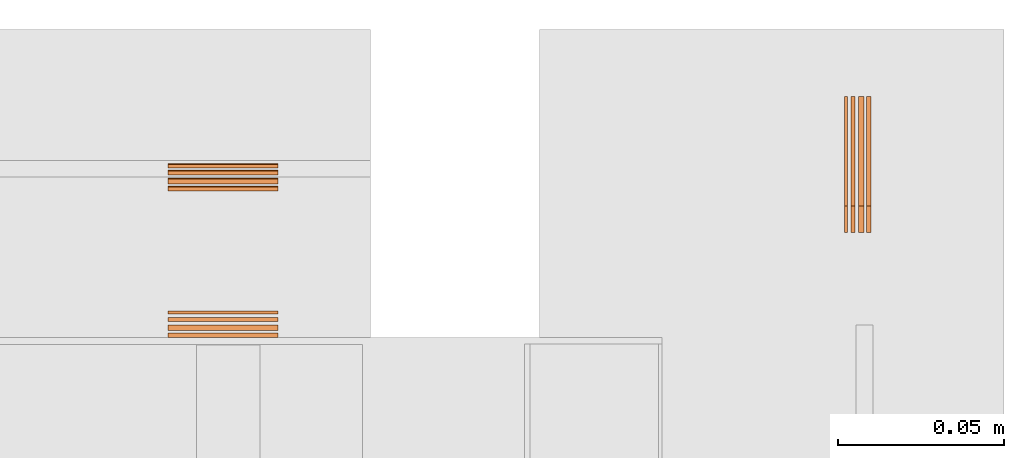
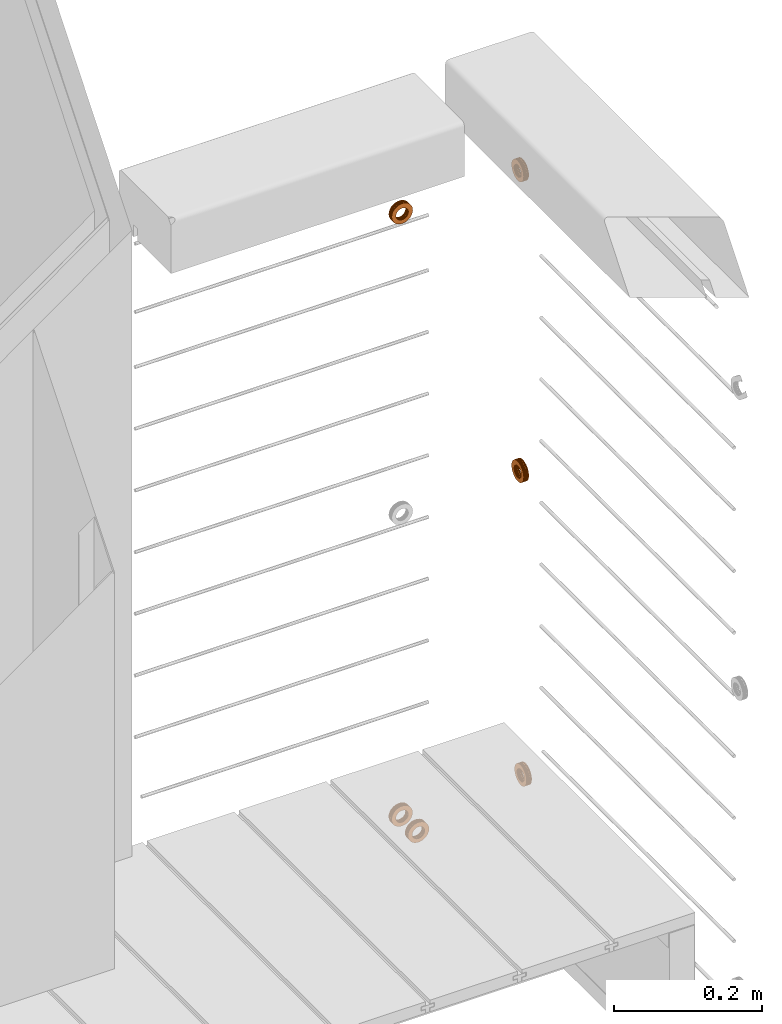
# One storey, part 33 of 33: 6 proxies.
"""IFC4 building model written with IfcOpenShell, lengths in feet."""

import ifcopenshell
import ifcopenshell.guid

model = None  # the IFC model being written
_history = None  # IfcOwnerHistory: only IFC2X3 demands one
_inside = {}  # id of a spatial element -> (the spatial element, [elements in it])
_under = {}  # id of a project, library or spatial element -> (it, [spatial elements below it])
_declared = {}  # id of a project -> (the project, [libraries it declares])
_typed = {}  # id of a type object -> (the type object, [elements of that type])
_made_of = {}  # id of a material, layer set ... -> (it, [elements and type objects made of it])


def new_model(schema):
    """Start an empty IFC model of exactly this schema.

    Asked for "IFC4X3", IfcOpenShell would pick the latest addendum, in which some entities
    have other attributes; the version numbers below select the first issue.
    IFC2X3 requires an IfcOwnerHistory on every rooted entity: one is made here for all.
    """
    global model, _history
    if schema == "IFC4X3":
        model = ifcopenshell.file(schema_version=(4, 3, 0, 0))
    else:
        model = ifcopenshell.file(schema=schema)
    _inside.clear()
    _under.clear()
    _declared.clear()
    _typed.clear()
    _made_of.clear()
    _history = None
    if model.schema == "IFC2X3":
        org = make("IfcOrganization", Name="unknown")
        user = make(
            "IfcPersonAndOrganization",
            ThePerson=make("IfcPerson", FamilyName="unknown"),
            TheOrganization=org,
        )
        app = make(
            "IfcApplication",
            ApplicationDeveloper=org,
            Version="unknown",
            ApplicationFullName="unknown",
            ApplicationIdentifier="unknown",
        )
        _history = make(
            "IfcOwnerHistory",
            OwningUser=user,
            OwningApplication=app,
            ChangeAction="ADDED",
            CreationDate=0,
        )
    return model


def make(cls, **values):
    """One entity of the class cls with the attributes given. An attribute that is None is left unset."""
    return model.create_entity(
        cls, **{name: value for name, value in values.items() if value is not None}
    )


def entity(cls, *values):
    """Any entity or typed value of the class cls, its attributes in the order of the schema. None: left unset."""
    e = model.create_entity(cls)
    for i, value in enumerate(values):
        if value is not None:
            e[i] = value
    return e


def rooted(cls, **values):
    """An entity with a GlobalId (a new one), such as an element, a storey or a relation."""
    return make(cls, GlobalId=ifcopenshell.guid.new(), OwnerHistory=_history, **values)


def si_unit(unit_type, name, prefix=None):
    """IfcSIUnit, for example si_unit("LENGTHUNIT", "METRE", prefix="MILLI")."""
    return make("IfcSIUnit", UnitType=unit_type, Prefix=prefix, Name=name)


def converted_unit(unit_type, name, factor, base, dimensions=None, offset=None):
    """IfcConversionBasedUnit, such as the inch: factor (a typed value) times the base unit."""
    return make(
        "IfcConversionBasedUnit"
        if offset is None
        else "IfcConversionBasedUnitWithOffset",
        ConversionOffset=offset,
        Dimensions=None
        if dimensions is None
        else entity("IfcDimensionalExponents", *dimensions),
        UnitType=unit_type,
        Name=name,
        ConversionFactor=make(
            "IfcMeasureWithUnit", ValueComponent=factor, UnitComponent=base
        ),
    )


def derived_unit(unit_type, elements):
    """IfcDerivedUnit: a product of units, each with its exponent."""
    return make(
        "IfcDerivedUnit",
        Elements=[
            make("IfcDerivedUnitElement", Unit=unit, Exponent=power)
            for unit, power in elements
        ],
        UnitType=unit_type,
    )


def assignment(units):
    """IfcUnitAssignment: the units of a project."""
    return None if units is None else make("IfcUnitAssignment", Units=units)


def point(xyz):
    """IfcCartesianPoint."""
    return None if xyz is None else make("IfcCartesianPoint", Coordinates=xyz)


def direction(xyz):
    """IfcDirection."""
    return None if xyz is None else make("IfcDirection", DirectionRatios=xyz)


def frame(location, z_axis=None, x_axis=None):
    """IfcAxis2Placement3D, a coordinate frame: its origin and axes. An axis left out is left unset."""
    return make(
        "IfcAxis2Placement3D",
        Location=point(location),
        Axis=direction(z_axis),
        RefDirection=direction(x_axis),
    )


def frame_2d(location, x_axis=None):
    """IfcAxis2Placement2D, a coordinate frame in the plane: its origin and x axis."""
    return make(
        "IfcAxis2Placement2D", Location=point(location), RefDirection=direction(x_axis)
    )


def origin():
    """The frame at (0, 0, 0) with its axes left unset."""
    return frame((0.0, 0.0, 0.0))


def origin_2d_with_axis():
    """The frame at (0, 0) in the plane with the x axis (1, 0) written out."""
    return frame_2d((0.0, 0.0), x_axis=(1.0, 0.0))


def place(relative_to, where):
    """IfcLocalPlacement: puts the frame where relative to a parent placement (None: the world)."""
    return make(
        "IfcLocalPlacement", PlacementRelTo=relative_to, RelativePlacement=where
    )


def context(
    kind, dimensions, precision=None, world=None, true_north=None, identifier=None
):
    """IfcGeometricRepresentationContext, for example the 3D "Model" context."""
    return make(
        "IfcGeometricRepresentationContext",
        ContextIdentifier=identifier,
        ContextType=kind,
        CoordinateSpaceDimension=dimensions,
        Precision=precision,
        WorldCoordinateSystem=world,
        TrueNorth=true_north,
    )


def subcontext(parent, identifier, kind, view, scale=None):
    """IfcGeometricRepresentationSubContext, for example "Body" below "Model"."""
    return make(
        "IfcGeometricRepresentationSubContext",
        ContextIdentifier=identifier,
        ContextType=kind,
        ParentContext=parent,
        TargetScale=scale,
        TargetView=view,
    )


def project(units=None, contexts=None):
    """IfcProject with its units and contexts."""
    return rooted(
        "IfcProject",
        Name="project",
        RepresentationContexts=contexts,
        UnitsInContext=assignment(units),
    )


def spatial(cls, under=None, at=None, **own):
    """A site, building, storey or space (cls), placed at a placement, below another one or the project."""
    s = rooted(cls, ObjectPlacement=at, **own)
    if under is not None:
        _under.setdefault(under.id(), (under, []))[1].append(s)
    return s


def circle_curve(where, radius):
    """IfcCircle in the frame where."""
    return make("IfcCircle", Position=where, Radius=radius)


def parameter(value):
    """IfcParameterValue: where a trimmed curve begins or ends, as a parameter of its basis curve."""
    return model.create_entity("IfcParameterValue", value)


def trimmed(basis, trim1, trim2, sense, master):
    """IfcTrimmedCurve: the piece of a basis curve between two trims."""
    return make(
        "IfcTrimmedCurve",
        BasisCurve=basis,
        Trim1=trim1,
        Trim2=trim2,
        SenseAgreement=sense,
        MasterRepresentation=master,
    )


def segment(curve, same_sense, transition):
    """IfcCompositeCurveSegment."""
    return make(
        "IfcCompositeCurveSegment",
        Transition=transition,
        SameSense=same_sense,
        ParentCurve=curve,
    )


def composite_curve(segments, self_intersect=None):
    """IfcCompositeCurve: segments joined end to end."""
    return make("IfcCompositeCurve", Segments=segments, SelfIntersect=self_intersect)


def outline(outer, holes=None, kind="AREA"):
    """IfcArbitraryClosedProfileDef: a profile drawn as a closed curve; with holes, ...WithVoids."""
    if holes is None:
        return make("IfcArbitraryClosedProfileDef", ProfileType=kind, OuterCurve=outer)
    return make(
        "IfcArbitraryProfileDefWithVoids",
        ProfileType=kind,
        OuterCurve=outer,
        InnerCurves=holes,
    )


def extrude(swept, where, along, depth):
    """IfcExtrudedAreaSolid: the profile swept, set in the frame where, extruded along a direction by depth."""
    return make(
        "IfcExtrudedAreaSolid",
        SweptArea=swept,
        Position=where,
        ExtrudedDirection=direction(along),
        Depth=depth,
    )


def shape(context_of_items, identifier, shape_type, items):
    """IfcShapeRepresentation: the items that make up one representation, for example the "Body"."""
    return make(
        "IfcShapeRepresentation",
        ContextOfItems=context_of_items,
        RepresentationIdentifier=identifier,
        RepresentationType=shape_type,
        Items=items,
    )


def source(mapping_origin, context_of_items, identifier, shape_type, items):
    """IfcRepresentationMap: a shape defined once, which mapped items show again and again."""
    return make(
        "IfcRepresentationMap",
        MappingOrigin=mapping_origin,
        MappedRepresentation=shape(context_of_items, identifier, shape_type, items),
    )


def transform(
    local_origin,
    x_axis=None,
    y_axis=None,
    z_axis=None,
    scale=None,
    scale2=None,
    scale3=None,
    uniform=True,
):
    """IfcCartesianTransformationOperator3D, or its non-uniform kind. x_axis, y_axis, z_axis: its Axis1, 2, 3."""
    if uniform:
        return make(
            "IfcCartesianTransformationOperator3D",
            Axis1=direction(x_axis),
            Axis2=direction(y_axis),
            LocalOrigin=point(local_origin),
            Scale=scale,
            Axis3=direction(z_axis),
        )
    return make(
        "IfcCartesianTransformationOperator3DnonUniform",
        Axis1=direction(x_axis),
        Axis2=direction(y_axis),
        LocalOrigin=point(local_origin),
        Scale=scale,
        Axis3=direction(z_axis),
        Scale2=scale2,
        Scale3=scale3,
    )


def mapped(mapping_source, mapping_target):
    """IfcMappedItem: shows the shape of a source again, moved by a transform."""
    return make(
        "IfcMappedItem", MappingSource=mapping_source, MappingTarget=mapping_target
    )


def material(Name=None, Category=None):
    """IfcMaterial."""
    return make("IfcMaterial", Name=Name, Category=Category)


def made_of(thing, what):
    """Note that an element or type object is made of a material, layer set ...; save() writes the relation."""
    if what is not None:
        _made_of.setdefault(what.id(), (what, []))[1].append(thing)
    return thing


def type_object(cls, material=None, **own):
    """A type object (cls), such as IfcWallType, which elements share."""
    return made_of(rooted(cls, **own), material)


def type_shapes(of_type, sources):
    """Give a type object the sources (RepresentationMaps) that its elements show as mapped items."""
    of_type.RepresentationMaps = sources


def element(
    cls,
    number,
    at=None,
    inside=None,
    cuts=None,
    type_object=None,
    material=None,
    context=None,
    identifier="Body",
    shape_type=None,
    held_by="IfcProductDefinitionShape",
    body=None,
    shapes=None,
    **own,
):
    """One element of the class cls, such as IfcWall. Its Tag is "e" and its number.

    at: its placement. inside: the storey or other place that contains it. cuts: it is an
    opening in that element (IfcRelVoidsElement). A single representation is given by context,
    identifier, shape_type and body (its items); several are given by shapes. held_by: the class
    of the entity that holds the representations. save() writes the other relations.
    """
    e = rooted(cls, Tag="e%d" % number, ObjectPlacement=at, **own)
    if body is not None:
        shapes = [shape(context, identifier, shape_type, body)]
    if shapes is not None:
        e.Representation = make(held_by, Representations=shapes)
    if inside is not None:
        _inside.setdefault(inside.id(), (inside, []))[1].append(e)
    if cuts is not None:
        rooted(
            "IfcRelVoidsElement", RelatingBuildingElement=cuts, RelatedOpeningElement=e
        )
    if type_object is not None:
        _typed.setdefault(type_object.id(), (type_object, []))[1].append(e)
    return made_of(e, material)


def aggregate(whole, parts):
    """IfcRelAggregates: a whole, such as a stair, and the parts it consists of."""
    return rooted("IfcRelAggregates", RelatingObject=whole, RelatedObjects=parts)


def save(model, path):
    """Write the relations noted so far, then the file.

    IfcRelAggregates (storeys below a building ...), IfcRelContainedInSpatialStructure (elements
    in a storey), IfcRelDefinesByType, IfcRelAssociatesMaterial and IfcRelDeclares: one each for
    every whole, place, type object, material and project.
    """
    for whole, parts in _under.values():
        aggregate(whole, parts)
    for where, things in _inside.values():
        rooted(
            "IfcRelContainedInSpatialStructure",
            RelatedElements=things,
            RelatingStructure=where,
        )
    for kind, things in _typed.values():
        rooted("IfcRelDefinesByType", RelatedObjects=things, RelatingType=kind)
    for what, things in _made_of.values():
        rooted("IfcRelAssociatesMaterial", RelatedObjects=things, RelatingMaterial=what)
    for by, libraries in _declared.values():
        rooted("IfcRelDeclares", RelatingContext=by, RelatedDefinitions=libraries)
    model.write(path)


model = new_model("IFC4")

# Units and contexts
model_context = context("Model", 3, precision=0.0001, world=origin(), true_north=direction((6.12303176911189e-17, 1.0)))
body_context = subcontext(model_context, "Body", "Model", "MODEL_VIEW")
ifc_project = project(units=[converted_unit("LENGTHUNIT", "FOOT", entity("IfcRatioMeasure", 0.3048), si_unit("LENGTHUNIT", "METRE"), dimensions=[1, 0, 0, 0, 0, 0, 0]), converted_unit("AREAUNIT", "SQUARE FOOT", entity("IfcRatioMeasure", 0.09290304), si_unit("AREAUNIT", "SQUARE_METRE"), dimensions=[2, 0, 0, 0, 0, 0, 0]), converted_unit("VOLUMEUNIT", "CUBIC FOOT", entity("IfcRatioMeasure", 0.028316846592), si_unit("VOLUMEUNIT", "CUBIC_METRE"), dimensions=[3, 0, 0, 0, 0, 0, 0]), converted_unit("PLANEANGLEUNIT", "DEGREE", entity("IfcRatioMeasure", 0.0174532925199433), si_unit("PLANEANGLEUNIT", "RADIAN"), dimensions=[0, 0, 0, 0, 0, 0, 0]), si_unit("MASSUNIT", "GRAM", prefix="KILO"), derived_unit("MASSDENSITYUNIT", [(si_unit("MASSUNIT", "GRAM", prefix="KILO"), 1), (si_unit("LENGTHUNIT", "METRE"), -3)]), derived_unit("MOMENTOFINERTIAUNIT", [(si_unit("LENGTHUNIT", "METRE"), 4)]), si_unit("TIMEUNIT", "SECOND"), si_unit("FREQUENCYUNIT", "HERTZ"), si_unit("THERMODYNAMICTEMPERATUREUNIT", "DEGREE_CELSIUS"), derived_unit("THERMALTRANSMITTANCEUNIT", [(si_unit("MASSUNIT", "GRAM", prefix="KILO"), 1), (si_unit("THERMODYNAMICTEMPERATUREUNIT", "KELVIN"), -1), (si_unit("TIMEUNIT", "SECOND"), -3)]), derived_unit("VOLUMETRICFLOWRATEUNIT", [(si_unit("LENGTHUNIT", "METRE"), 3), (si_unit("TIMEUNIT", "SECOND"), -1)]), si_unit("ELECTRICCURRENTUNIT", "AMPERE"), si_unit("ELECTRICVOLTAGEUNIT", "VOLT"), si_unit("POWERUNIT", "WATT"), si_unit("FORCEUNIT", "NEWTON"), si_unit("ILLUMINANCEUNIT", "LUX"), si_unit("LUMINOUSFLUXUNIT", "LUMEN"), si_unit("LUMINOUSINTENSITYUNIT", "CANDELA"), derived_unit("USERDEFINED", [(si_unit("MASSUNIT", "GRAM", prefix="KILO"), -1), (si_unit("LENGTHUNIT", "METRE"), -2), (si_unit("TIMEUNIT", "SECOND"), 3), (si_unit("LUMINOUSFLUXUNIT", "LUMEN"), 1)]), derived_unit("LINEARVELOCITYUNIT", [(si_unit("LENGTHUNIT", "METRE"), 1), (si_unit("TIMEUNIT", "SECOND"), -1)]), si_unit("PRESSUREUNIT", "PASCAL"), derived_unit("USERDEFINED", [(si_unit("LENGTHUNIT", "METRE"), -2), (si_unit("MASSUNIT", "GRAM", prefix="KILO"), 1), (si_unit("TIMEUNIT", "SECOND"), -2)]), derived_unit("LINEARFORCEUNIT", [(si_unit("MASSUNIT", "GRAM", prefix="KILO"), 1), (si_unit("LENGTHUNIT", "METRE"), 1), (si_unit("TIMEUNIT", "SECOND"), -2), (si_unit("LENGTHUNIT", "METRE"), -1)]), derived_unit("PLANARFORCEUNIT", [(si_unit("MASSUNIT", "GRAM", prefix="KILO"), 1), (si_unit("LENGTHUNIT", "METRE"), 1), (si_unit("TIMEUNIT", "SECOND"), -2), (si_unit("LENGTHUNIT", "METRE"), -2)])], contexts=[model_context])

# Site, building, storey
site_placement = place(None, origin())
site = spatial("IfcSite", under=ifc_project, at=site_placement, CompositionType="ELEMENT")
building_placement = place(site_placement, origin())
building = spatial("IfcBuilding", under=site, at=building_placement, CompositionType="ELEMENT")
storey_placement = place(building_placement, frame((0.0, 0.0, 10.0)))
storey = spatial("IfcBuildingStorey", under=building, at=storey_placement, Name="2ND FLOOR", CompositionType="ELEMENT", Elevation=10.0000000000002)

# Proxies
ifc_material = material(Name="(2) GALV. (FOR DRAINAGE)", Category="Materials")
building_element_proxy_type_1 = type_object("IfcBuildingElementProxyType", Name="WASHER237:WASHER", PredefinedType="NOTDEFINED", material=ifc_material)
shared_shape_1 = source(origin(), body_context, "Body", "SweptSolid", [
    extrude(outline(composite_curve([segment(trimmed(circle_curve(origin_2d_with_axis(), 0.054126587736544), [parameter(360.0)], [parameter(180.0)], True, "PARAMETER"), True, "CONTINUOUS"), segment(trimmed(circle_curve(origin_2d_with_axis(), 0.054126587736544), [parameter(180.0)], [parameter(360.0)], True, "PARAMETER"), True, "CONTINUOUS")], self_intersect=False), holes=[composite_curve([segment(trimmed(circle_curve(frame_2d((0.0, 0.00204962727015712), x_axis=(1.0, 0.0)), 0.031438579453031), [parameter(180.0)], [parameter(360.0)], True, "PARAMETER"), False, "CONTINUOUS"), segment(trimmed(circle_curve(frame_2d((0.0, 0.00204962727015712), x_axis=(1.0, 0.0)), 0.031438579453031), [parameter(360.0)], [parameter(180.0)], True, "PARAMETER"), False, "CONTINUOUS")], self_intersect=False)]), frame((0.0, 0.0593604205315437, 0.0593604205315437), z_axis=(1.0, 0.0, 0.0), x_axis=(0.0, -1.0, 0.0)), (0.0, 0.0, 1.0), 0.00332179672204802),
    extrude(outline(composite_curve([segment(trimmed(circle_curve(origin_2d_with_axis(), 0.054126587736544), [parameter(180.0)], [parameter(360.0)], True, "PARAMETER"), True, "CONTINUOUS"), segment(trimmed(circle_curve(origin_2d_with_axis(), 0.054126587736544), [parameter(360.0)], [parameter(180.0)], True, "PARAMETER"), True, "CONTINUOUS")], self_intersect=False), holes=[composite_curve([segment(trimmed(circle_curve(frame_2d((0.0, 0.00204962727015712), x_axis=(1.0, 0.0)), 0.031438579453031), [parameter(360.0)], [parameter(180.0)], True, "PARAMETER"), False, "CONTINUOUS"), segment(trimmed(circle_curve(frame_2d((0.0, 0.00204962727015712), x_axis=(1.0, 0.0)), 0.031438579453031), [parameter(180.0)], [parameter(360.0)], True, "PARAMETER"), False, "CONTINUOUS")], self_intersect=False)]), frame((0.0220636819910851, 0.0593604205315437, 0.0593604205315437), z_axis=(1.0, 0.0, 0.0), x_axis=(0.0, -1.0, 0.0)), (0.0, 0.0, 1.0), 0.00404999031002262),
    extrude(outline(composite_curve([segment(trimmed(circle_curve(origin_2d_with_axis(), 0.054126587736544), [parameter(180.0)], [parameter(360.0)], True, "PARAMETER"), True, "CONTINUOUS"), segment(trimmed(circle_curve(origin_2d_with_axis(), 0.054126587736544), [parameter(360.0)], [parameter(180.0)], True, "PARAMETER"), True, "CONTINUOUS")], self_intersect=False), holes=[composite_curve([segment(trimmed(circle_curve(frame_2d((0.0, 0.00204962727015712), x_axis=(1.0, 0.0)), 0.031438579453031), [parameter(360.0)], [parameter(180.0)], True, "PARAMETER"), False, "CONTINUOUS"), segment(trimmed(circle_curve(frame_2d((0.0, 0.00204962727015712), x_axis=(1.0, 0.0)), 0.031438579453031), [parameter(180.0)], [parameter(360.0)], True, "PARAMETER"), False, "CONTINUOUS")], self_intersect=False)]), frame((0.00642093526334975, 0.0593604205315437, 0.0593604205315437), z_axis=(1.0, 0.0, 0.0), x_axis=(0.0, -1.0, 0.0)), (0.0, 0.0, 1.0), 0.00412198282083409),
    extrude(outline(composite_curve([segment(trimmed(circle_curve(origin_2d_with_axis(), 0.054126587736544), [parameter(180.0)], [parameter(360.0)], True, "PARAMETER"), True, "CONTINUOUS"), segment(trimmed(circle_curve(origin_2d_with_axis(), 0.054126587736544), [parameter(360.0)], [parameter(180.0)], True, "PARAMETER"), True, "CONTINUOUS")], self_intersect=False), holes=[composite_curve([segment(trimmed(circle_curve(frame_2d((0.0, 0.00204962727015712), x_axis=(1.0, 0.0)), 0.031438579453031), [parameter(360.0)], [parameter(180.0)], True, "PARAMETER"), False, "CONTINUOUS"), segment(trimmed(circle_curve(frame_2d((0.0, 0.00204962727015712), x_axis=(1.0, 0.0)), 0.031438579453031), [parameter(180.0)], [parameter(360.0)], True, "PARAMETER"), False, "CONTINUOUS")], self_intersect=False)]), frame((0.0141095597130061, 0.0593604205315437, 0.0593604205315437), z_axis=(1.0, 0.0, 0.0), x_axis=(0.0, -1.0, 0.0)), (0.0, 0.0, 1.0), 0.0051228935196832),
])
type_shapes(building_element_proxy_type_1, [shared_shape_1])
proxy_1_placement = place(storey_placement, frame((1493.80418979036, 4.91616431605937, 3.49574875459465), z_axis=(0.0, 0.0, 1.0), x_axis=(0.0, -1.0, 0.0)))
element("IfcBuildingElementProxy", 1, at=proxy_1_placement, inside=storey, type_object=building_element_proxy_type_1, material=ifc_material, Name="WASHER237:WASHER", ObjectType="WASHER237:WASHER", PredefinedType="NOTDEFINED", context=body_context, shape_type="MappedRepresentation", body=[
    mapped(shared_shape_1, transform((0.0, 0.0, 0.0), scale=1.0)),
])
building_element_proxy_type_2 = type_object("IfcBuildingElementProxyType", Name="WASHER203:WASHER", PredefinedType="NOTDEFINED", material=ifc_material)
shared_shape_2 = source(origin(), body_context, "Body", "SweptSolid", [
    extrude(outline(composite_curve([segment(trimmed(circle_curve(origin_2d_with_axis(), 0.054126587736544), [parameter(360.0)], [parameter(180.0)], True, "PARAMETER"), True, "CONTINUOUS"), segment(trimmed(circle_curve(origin_2d_with_axis(), 0.054126587736544), [parameter(180.0)], [parameter(360.0)], True, "PARAMETER"), True, "CONTINUOUS")], self_intersect=False), holes=[composite_curve([segment(trimmed(circle_curve(frame_2d((0.0, 0.00204962727015712), x_axis=(1.0, 0.0)), 0.031438579453031), [parameter(180.0)], [parameter(360.0)], True, "PARAMETER"), False, "CONTINUOUS"), segment(trimmed(circle_curve(frame_2d((0.0, 0.00204962727015712), x_axis=(1.0, 0.0)), 0.031438579453031), [parameter(360.0)], [parameter(180.0)], True, "PARAMETER"), False, "CONTINUOUS")], self_intersect=False)]), frame((0.0, 0.0593604205315437, 0.0593604205315437), z_axis=(1.0, 0.0, 0.0), x_axis=(0.0, -1.0, 0.0)), (0.0, 0.0, 1.0), 0.00332179672204802),
    extrude(outline(composite_curve([segment(trimmed(circle_curve(origin_2d_with_axis(), 0.054126587736544), [parameter(180.0)], [parameter(360.0)], True, "PARAMETER"), True, "CONTINUOUS"), segment(trimmed(circle_curve(origin_2d_with_axis(), 0.054126587736544), [parameter(360.0)], [parameter(180.0)], True, "PARAMETER"), True, "CONTINUOUS")], self_intersect=False), holes=[composite_curve([segment(trimmed(circle_curve(frame_2d((0.0, 0.00204962727015712), x_axis=(1.0, 0.0)), 0.031438579453031), [parameter(360.0)], [parameter(180.0)], True, "PARAMETER"), False, "CONTINUOUS"), segment(trimmed(circle_curve(frame_2d((0.0, 0.00204962727015712), x_axis=(1.0, 0.0)), 0.031438579453031), [parameter(180.0)], [parameter(360.0)], True, "PARAMETER"), False, "CONTINUOUS")], self_intersect=False)]), frame((0.0220636819910851, 0.0593604205315437, 0.0593604205315437), z_axis=(1.0, 0.0, 0.0), x_axis=(0.0, -1.0, 0.0)), (0.0, 0.0, 1.0), 0.00404999031002262),
    extrude(outline(composite_curve([segment(trimmed(circle_curve(origin_2d_with_axis(), 0.054126587736544), [parameter(180.0)], [parameter(360.0)], True, "PARAMETER"), True, "CONTINUOUS"), segment(trimmed(circle_curve(origin_2d_with_axis(), 0.054126587736544), [parameter(360.0)], [parameter(180.0)], True, "PARAMETER"), True, "CONTINUOUS")], self_intersect=False), holes=[composite_curve([segment(trimmed(circle_curve(frame_2d((0.0, 0.00204962727015712), x_axis=(1.0, 0.0)), 0.031438579453031), [parameter(360.0)], [parameter(180.0)], True, "PARAMETER"), False, "CONTINUOUS"), segment(trimmed(circle_curve(frame_2d((0.0, 0.00204962727015712), x_axis=(1.0, 0.0)), 0.031438579453031), [parameter(180.0)], [parameter(360.0)], True, "PARAMETER"), False, "CONTINUOUS")], self_intersect=False)]), frame((0.00642093526334975, 0.0593604205315437, 0.0593604205315437), z_axis=(1.0, 0.0, 0.0), x_axis=(0.0, -1.0, 0.0)), (0.0, 0.0, 1.0), 0.00412198282083409),
    extrude(outline(composite_curve([segment(trimmed(circle_curve(origin_2d_with_axis(), 0.054126587736544), [parameter(180.0)], [parameter(360.0)], True, "PARAMETER"), True, "CONTINUOUS"), segment(trimmed(circle_curve(origin_2d_with_axis(), 0.054126587736544), [parameter(360.0)], [parameter(180.0)], True, "PARAMETER"), True, "CONTINUOUS")], self_intersect=False), holes=[composite_curve([segment(trimmed(circle_curve(frame_2d((0.0, 0.00204962727015712), x_axis=(1.0, 0.0)), 0.031438579453031), [parameter(360.0)], [parameter(180.0)], True, "PARAMETER"), False, "CONTINUOUS"), segment(trimmed(circle_curve(frame_2d((0.0, 0.00204962727015712), x_axis=(1.0, 0.0)), 0.031438579453031), [parameter(180.0)], [parameter(360.0)], True, "PARAMETER"), False, "CONTINUOUS")], self_intersect=False)]), frame((0.0141095597130061, 0.0593604205315437, 0.0593604205315437), z_axis=(1.0, 0.0, 0.0), x_axis=(0.0, -1.0, 0.0)), (0.0, 0.0, 1.0), 0.0051228935196832),
])
type_shapes(building_element_proxy_type_2, [shared_shape_2])
proxy_2_placement = place(storey_placement, frame((1493.80418979036, 4.9172173612744, 0.240013314993284), z_axis=(0.0, 0.0, 1.0), x_axis=(0.0, -1.0, 0.0)))
element("IfcBuildingElementProxy", 2, at=proxy_2_placement, inside=storey, type_object=building_element_proxy_type_2, material=ifc_material, Name="WASHER203:WASHER", ObjectType="WASHER203:WASHER", PredefinedType="NOTDEFINED", context=body_context, shape_type="MappedRepresentation", body=[
    mapped(shared_shape_2, transform((0.0, 0.0, 0.0), scale=1.0)),
])
building_element_proxy_type_3 = type_object("IfcBuildingElementProxyType", Name="WASHER206:WASHER", PredefinedType="NOTDEFINED", material=ifc_material)
shared_shape_3 = source(origin(), body_context, "Body", "SweptSolid", [
    extrude(outline(composite_curve([segment(trimmed(circle_curve(origin_2d_with_axis(), 0.054126587736544), [parameter(360.0)], [parameter(180.0)], True, "PARAMETER"), True, "CONTINUOUS"), segment(trimmed(circle_curve(origin_2d_with_axis(), 0.054126587736544), [parameter(180.0)], [parameter(360.0)], True, "PARAMETER"), True, "CONTINUOUS")], self_intersect=False), holes=[composite_curve([segment(trimmed(circle_curve(frame_2d((0.0, 0.00204962727015712), x_axis=(1.0, 0.0)), 0.031438579453031), [parameter(180.0)], [parameter(360.0)], True, "PARAMETER"), False, "CONTINUOUS"), segment(trimmed(circle_curve(frame_2d((0.0, 0.00204962727015712), x_axis=(1.0, 0.0)), 0.031438579453031), [parameter(360.0)], [parameter(180.0)], True, "PARAMETER"), False, "CONTINUOUS")], self_intersect=False)]), frame((0.0, 0.0593604205315437, 0.0593604205315437), z_axis=(1.0, 0.0, 0.0), x_axis=(0.0, -1.0, 0.0)), (0.0, 0.0, 1.0), 0.00332179672204802),
    extrude(outline(composite_curve([segment(trimmed(circle_curve(origin_2d_with_axis(), 0.054126587736544), [parameter(180.0)], [parameter(360.0)], True, "PARAMETER"), True, "CONTINUOUS"), segment(trimmed(circle_curve(origin_2d_with_axis(), 0.054126587736544), [parameter(360.0)], [parameter(180.0)], True, "PARAMETER"), True, "CONTINUOUS")], self_intersect=False), holes=[composite_curve([segment(trimmed(circle_curve(frame_2d((0.0, 0.00204962727015712), x_axis=(1.0, 0.0)), 0.031438579453031), [parameter(360.0)], [parameter(180.0)], True, "PARAMETER"), False, "CONTINUOUS"), segment(trimmed(circle_curve(frame_2d((0.0, 0.00204962727015712), x_axis=(1.0, 0.0)), 0.031438579453031), [parameter(180.0)], [parameter(360.0)], True, "PARAMETER"), False, "CONTINUOUS")], self_intersect=False)]), frame((0.0220636819910851, 0.0593604205315437, 0.0593604205315437), z_axis=(1.0, 0.0, 0.0), x_axis=(0.0, -1.0, 0.0)), (0.0, 0.0, 1.0), 0.00404999031002262),
    extrude(outline(composite_curve([segment(trimmed(circle_curve(origin_2d_with_axis(), 0.054126587736544), [parameter(180.0)], [parameter(360.0)], True, "PARAMETER"), True, "CONTINUOUS"), segment(trimmed(circle_curve(origin_2d_with_axis(), 0.054126587736544), [parameter(360.0)], [parameter(180.0)], True, "PARAMETER"), True, "CONTINUOUS")], self_intersect=False), holes=[composite_curve([segment(trimmed(circle_curve(frame_2d((0.0, 0.00204962727015712), x_axis=(1.0, 0.0)), 0.031438579453031), [parameter(360.0)], [parameter(180.0)], True, "PARAMETER"), False, "CONTINUOUS"), segment(trimmed(circle_curve(frame_2d((0.0, 0.00204962727015712), x_axis=(1.0, 0.0)), 0.031438579453031), [parameter(180.0)], [parameter(360.0)], True, "PARAMETER"), False, "CONTINUOUS")], self_intersect=False)]), frame((0.00642093526334975, 0.0593604205315437, 0.0593604205315437), z_axis=(1.0, 0.0, 0.0), x_axis=(0.0, -1.0, 0.0)), (0.0, 0.0, 1.0), 0.00412198282083409),
    extrude(outline(composite_curve([segment(trimmed(circle_curve(origin_2d_with_axis(), 0.054126587736544), [parameter(180.0)], [parameter(360.0)], True, "PARAMETER"), True, "CONTINUOUS"), segment(trimmed(circle_curve(origin_2d_with_axis(), 0.054126587736544), [parameter(360.0)], [parameter(180.0)], True, "PARAMETER"), True, "CONTINUOUS")], self_intersect=False), holes=[composite_curve([segment(trimmed(circle_curve(frame_2d((0.0, 0.00204962727015712), x_axis=(1.0, 0.0)), 0.031438579453031), [parameter(360.0)], [parameter(180.0)], True, "PARAMETER"), False, "CONTINUOUS"), segment(trimmed(circle_curve(frame_2d((0.0, 0.00204962727015712), x_axis=(1.0, 0.0)), 0.031438579453031), [parameter(180.0)], [parameter(360.0)], True, "PARAMETER"), False, "CONTINUOUS")], self_intersect=False)]), frame((0.0141095597130061, 0.0593604205315437, 0.0593604205315437), z_axis=(1.0, 0.0, 0.0), x_axis=(0.0, -1.0, 0.0)), (0.0, 0.0, 1.0), 0.0051228935196832),
])
type_shapes(building_element_proxy_type_3, [shared_shape_3])
proxy_3_placement = place(storey_placement, frame((1493.80418979036, 4.77190511208776, 0.240013314993284), z_axis=(0.0, 0.0, 1.0), x_axis=(0.0, -1.0, 0.0)))
element("IfcBuildingElementProxy", 3, at=proxy_3_placement, inside=storey, type_object=building_element_proxy_type_3, material=ifc_material, Name="WASHER206:WASHER", ObjectType="WASHER206:WASHER", PredefinedType="NOTDEFINED", context=body_context, shape_type="MappedRepresentation", body=[
    mapped(shared_shape_3, transform((0.0, 0.0, 0.0), scale=1.0)),
])
building_element_proxy_type_4 = type_object("IfcBuildingElementProxyType", Name="WASHER316:WASHER", PredefinedType="NOTDEFINED", material=ifc_material)
shared_shape_4 = source(origin(), body_context, "Body", "SweptSolid", [
    extrude(outline(composite_curve([segment(trimmed(circle_curve(origin_2d_with_axis(), 0.054126587736544), [parameter(360.0)], [parameter(180.0)], True, "PARAMETER"), True, "CONTINUOUS"), segment(trimmed(circle_curve(origin_2d_with_axis(), 0.054126587736544), [parameter(180.0)], [parameter(360.0)], True, "PARAMETER"), True, "CONTINUOUS")], self_intersect=False), holes=[composite_curve([segment(trimmed(circle_curve(frame_2d((0.0, 0.00204962727015712), x_axis=(1.0, 0.0)), 0.031438579453031), [parameter(180.0)], [parameter(360.0)], True, "PARAMETER"), False, "CONTINUOUS"), segment(trimmed(circle_curve(frame_2d((0.0, 0.00204962727015712), x_axis=(1.0, 0.0)), 0.031438579453031), [parameter(360.0)], [parameter(180.0)], True, "PARAMETER"), False, "CONTINUOUS")], self_intersect=False)]), frame((0.0, 0.0593604205315437, 0.0593604205315437), z_axis=(1.0, 0.0, 0.0), x_axis=(0.0, -1.0, 0.0)), (0.0, 0.0, 1.0), 0.00332179672204802),
    extrude(outline(composite_curve([segment(trimmed(circle_curve(origin_2d_with_axis(), 0.054126587736544), [parameter(180.0)], [parameter(360.0)], True, "PARAMETER"), True, "CONTINUOUS"), segment(trimmed(circle_curve(origin_2d_with_axis(), 0.054126587736544), [parameter(360.0)], [parameter(180.0)], True, "PARAMETER"), True, "CONTINUOUS")], self_intersect=False), holes=[composite_curve([segment(trimmed(circle_curve(frame_2d((0.0, 0.00204962727015712), x_axis=(1.0, 0.0)), 0.031438579453031), [parameter(360.0)], [parameter(180.0)], True, "PARAMETER"), False, "CONTINUOUS"), segment(trimmed(circle_curve(frame_2d((0.0, 0.00204962727015712), x_axis=(1.0, 0.0)), 0.031438579453031), [parameter(180.0)], [parameter(360.0)], True, "PARAMETER"), False, "CONTINUOUS")], self_intersect=False)]), frame((0.0220636819910851, 0.0593604205315437, 0.0593604205315437), z_axis=(1.0, 0.0, 0.0), x_axis=(0.0, -1.0, 0.0)), (0.0, 0.0, 1.0), 0.00404999031002262),
    extrude(outline(composite_curve([segment(trimmed(circle_curve(origin_2d_with_axis(), 0.054126587736544), [parameter(180.0)], [parameter(360.0)], True, "PARAMETER"), True, "CONTINUOUS"), segment(trimmed(circle_curve(origin_2d_with_axis(), 0.054126587736544), [parameter(360.0)], [parameter(180.0)], True, "PARAMETER"), True, "CONTINUOUS")], self_intersect=False), holes=[composite_curve([segment(trimmed(circle_curve(frame_2d((0.0, 0.00204962727015712), x_axis=(1.0, 0.0)), 0.031438579453031), [parameter(360.0)], [parameter(180.0)], True, "PARAMETER"), False, "CONTINUOUS"), segment(trimmed(circle_curve(frame_2d((0.0, 0.00204962727015712), x_axis=(1.0, 0.0)), 0.031438579453031), [parameter(180.0)], [parameter(360.0)], True, "PARAMETER"), False, "CONTINUOUS")], self_intersect=False)]), frame((0.00642093526334975, 0.0593604205315437, 0.0593604205315437), z_axis=(1.0, 0.0, 0.0), x_axis=(0.0, -1.0, 0.0)), (0.0, 0.0, 1.0), 0.00412198282083409),
    extrude(outline(composite_curve([segment(trimmed(circle_curve(origin_2d_with_axis(), 0.054126587736544), [parameter(180.0)], [parameter(360.0)], True, "PARAMETER"), True, "CONTINUOUS"), segment(trimmed(circle_curve(origin_2d_with_axis(), 0.054126587736544), [parameter(360.0)], [parameter(180.0)], True, "PARAMETER"), True, "CONTINUOUS")], self_intersect=False), holes=[composite_curve([segment(trimmed(circle_curve(frame_2d((0.0, 0.00204962727015712), x_axis=(1.0, 0.0)), 0.031438579453031), [parameter(360.0)], [parameter(180.0)], True, "PARAMETER"), False, "CONTINUOUS"), segment(trimmed(circle_curve(frame_2d((0.0, 0.00204962727015712), x_axis=(1.0, 0.0)), 0.031438579453031), [parameter(180.0)], [parameter(360.0)], True, "PARAMETER"), False, "CONTINUOUS")], self_intersect=False)]), frame((0.0141095597130061, 0.0593604205315437, 0.0593604205315437), z_axis=(1.0, 0.0, 0.0), x_axis=(0.0, -1.0, 0.0)), (0.0, 0.0, 1.0), 0.0051228935196832),
])
type_shapes(building_element_proxy_type_4, [shared_shape_4])
proxy_4_placement = place(storey_placement, frame((1494.47651830938, 4.84385605947604, 0.240013314992657)))
element("IfcBuildingElementProxy", 4, at=proxy_4_placement, inside=storey, type_object=building_element_proxy_type_4, material=ifc_material, Name="WASHER316:WASHER", ObjectType="WASHER316:WASHER", PredefinedType="NOTDEFINED", context=body_context, shape_type="MappedRepresentation", body=[
    mapped(shared_shape_4, transform((0.0, 0.0, 0.0), scale=1.0)),
])
building_element_proxy_type_5 = type_object("IfcBuildingElementProxyType", Name="WASHER319:WASHER", PredefinedType="NOTDEFINED", material=ifc_material)
shared_shape_5 = source(origin(), body_context, "Body", "SweptSolid", [
    extrude(outline(composite_curve([segment(trimmed(circle_curve(origin_2d_with_axis(), 0.054126587736544), [parameter(360.0)], [parameter(180.0)], True, "PARAMETER"), True, "CONTINUOUS"), segment(trimmed(circle_curve(origin_2d_with_axis(), 0.054126587736544), [parameter(180.0)], [parameter(360.0)], True, "PARAMETER"), True, "CONTINUOUS")], self_intersect=False), holes=[composite_curve([segment(trimmed(circle_curve(frame_2d((0.0, 0.00204962727015712), x_axis=(1.0, 0.0)), 0.031438579453031), [parameter(180.0)], [parameter(360.0)], True, "PARAMETER"), False, "CONTINUOUS"), segment(trimmed(circle_curve(frame_2d((0.0, 0.00204962727015712), x_axis=(1.0, 0.0)), 0.031438579453031), [parameter(360.0)], [parameter(180.0)], True, "PARAMETER"), False, "CONTINUOUS")], self_intersect=False)]), frame((0.0, 0.0593604205315437, 0.0593604205315437), z_axis=(1.0, 0.0, 0.0), x_axis=(0.0, -1.0, 0.0)), (0.0, 0.0, 1.0), 0.00332179672204802),
    extrude(outline(composite_curve([segment(trimmed(circle_curve(origin_2d_with_axis(), 0.054126587736544), [parameter(180.0)], [parameter(360.0)], True, "PARAMETER"), True, "CONTINUOUS"), segment(trimmed(circle_curve(origin_2d_with_axis(), 0.054126587736544), [parameter(360.0)], [parameter(180.0)], True, "PARAMETER"), True, "CONTINUOUS")], self_intersect=False), holes=[composite_curve([segment(trimmed(circle_curve(frame_2d((0.0, 0.00204962727015712), x_axis=(1.0, 0.0)), 0.031438579453031), [parameter(360.0)], [parameter(180.0)], True, "PARAMETER"), False, "CONTINUOUS"), segment(trimmed(circle_curve(frame_2d((0.0, 0.00204962727015712), x_axis=(1.0, 0.0)), 0.031438579453031), [parameter(180.0)], [parameter(360.0)], True, "PARAMETER"), False, "CONTINUOUS")], self_intersect=False)]), frame((0.0220636819910851, 0.0593604205315437, 0.0593604205315437), z_axis=(1.0, 0.0, 0.0), x_axis=(0.0, -1.0, 0.0)), (0.0, 0.0, 1.0), 0.00404999031002262),
    extrude(outline(composite_curve([segment(trimmed(circle_curve(origin_2d_with_axis(), 0.054126587736544), [parameter(180.0)], [parameter(360.0)], True, "PARAMETER"), True, "CONTINUOUS"), segment(trimmed(circle_curve(origin_2d_with_axis(), 0.054126587736544), [parameter(360.0)], [parameter(180.0)], True, "PARAMETER"), True, "CONTINUOUS")], self_intersect=False), holes=[composite_curve([segment(trimmed(circle_curve(frame_2d((0.0, 0.00204962727015712), x_axis=(1.0, 0.0)), 0.031438579453031), [parameter(360.0)], [parameter(180.0)], True, "PARAMETER"), False, "CONTINUOUS"), segment(trimmed(circle_curve(frame_2d((0.0, 0.00204962727015712), x_axis=(1.0, 0.0)), 0.031438579453031), [parameter(180.0)], [parameter(360.0)], True, "PARAMETER"), False, "CONTINUOUS")], self_intersect=False)]), frame((0.00642093526334975, 0.0593604205315437, 0.0593604205315437), z_axis=(1.0, 0.0, 0.0), x_axis=(0.0, -1.0, 0.0)), (0.0, 0.0, 1.0), 0.00412198282083409),
    extrude(outline(composite_curve([segment(trimmed(circle_curve(origin_2d_with_axis(), 0.054126587736544), [parameter(180.0)], [parameter(360.0)], True, "PARAMETER"), True, "CONTINUOUS"), segment(trimmed(circle_curve(origin_2d_with_axis(), 0.054126587736544), [parameter(360.0)], [parameter(180.0)], True, "PARAMETER"), True, "CONTINUOUS")], self_intersect=False), holes=[composite_curve([segment(trimmed(circle_curve(frame_2d((0.0, 0.00204962727015712), x_axis=(1.0, 0.0)), 0.031438579453031), [parameter(360.0)], [parameter(180.0)], True, "PARAMETER"), False, "CONTINUOUS"), segment(trimmed(circle_curve(frame_2d((0.0, 0.00204962727015712), x_axis=(1.0, 0.0)), 0.031438579453031), [parameter(180.0)], [parameter(360.0)], True, "PARAMETER"), False, "CONTINUOUS")], self_intersect=False)]), frame((0.0141095597130061, 0.0593604205315437, 0.0593604205315437), z_axis=(1.0, 0.0, 0.0), x_axis=(0.0, -1.0, 0.0)), (0.0, 0.0, 1.0), 0.0051228935196832),
])
type_shapes(building_element_proxy_type_5, [shared_shape_5])
proxy_5_placement = place(storey_placement, frame((1494.47651830938, 4.86995326323675, 1.86485859873615)))
element("IfcBuildingElementProxy", 5, at=proxy_5_placement, inside=storey, type_object=building_element_proxy_type_5, material=ifc_material, Name="WASHER319:WASHER", ObjectType="WASHER319:WASHER", PredefinedType="NOTDEFINED", context=body_context, shape_type="MappedRepresentation", body=[
    mapped(shared_shape_5, transform((0.0, 0.0, 0.0), scale=1.0)),
])
building_element_proxy_type_6 = type_object("IfcBuildingElementProxyType", Name="WASHER320:WASHER", PredefinedType="NOTDEFINED", material=ifc_material)
shared_shape_6 = source(origin(), body_context, "Body", "SweptSolid", [
    extrude(outline(composite_curve([segment(trimmed(circle_curve(origin_2d_with_axis(), 0.054126587736544), [parameter(360.0)], [parameter(180.0)], True, "PARAMETER"), True, "CONTINUOUS"), segment(trimmed(circle_curve(origin_2d_with_axis(), 0.054126587736544), [parameter(180.0)], [parameter(360.0)], True, "PARAMETER"), True, "CONTINUOUS")], self_intersect=False), holes=[composite_curve([segment(trimmed(circle_curve(frame_2d((0.0, 0.00204962727015712), x_axis=(1.0, 0.0)), 0.031438579453031), [parameter(180.0)], [parameter(360.0)], True, "PARAMETER"), False, "CONTINUOUS"), segment(trimmed(circle_curve(frame_2d((0.0, 0.00204962727015712), x_axis=(1.0, 0.0)), 0.031438579453031), [parameter(360.0)], [parameter(180.0)], True, "PARAMETER"), False, "CONTINUOUS")], self_intersect=False)]), frame((0.0, 0.0593604205315437, 0.0593604205315437), z_axis=(1.0, 0.0, 0.0), x_axis=(0.0, -1.0, 0.0)), (0.0, 0.0, 1.0), 0.00332179672204802),
    extrude(outline(composite_curve([segment(trimmed(circle_curve(origin_2d_with_axis(), 0.054126587736544), [parameter(180.0)], [parameter(360.0)], True, "PARAMETER"), True, "CONTINUOUS"), segment(trimmed(circle_curve(origin_2d_with_axis(), 0.054126587736544), [parameter(360.0)], [parameter(180.0)], True, "PARAMETER"), True, "CONTINUOUS")], self_intersect=False), holes=[composite_curve([segment(trimmed(circle_curve(frame_2d((0.0, 0.00204962727015712), x_axis=(1.0, 0.0)), 0.031438579453031), [parameter(360.0)], [parameter(180.0)], True, "PARAMETER"), False, "CONTINUOUS"), segment(trimmed(circle_curve(frame_2d((0.0, 0.00204962727015712), x_axis=(1.0, 0.0)), 0.031438579453031), [parameter(180.0)], [parameter(360.0)], True, "PARAMETER"), False, "CONTINUOUS")], self_intersect=False)]), frame((0.0220636819910851, 0.0593604205315437, 0.0593604205315437), z_axis=(1.0, 0.0, 0.0), x_axis=(0.0, -1.0, 0.0)), (0.0, 0.0, 1.0), 0.00404999031002262),
    extrude(outline(composite_curve([segment(trimmed(circle_curve(origin_2d_with_axis(), 0.054126587736544), [parameter(180.0)], [parameter(360.0)], True, "PARAMETER"), True, "CONTINUOUS"), segment(trimmed(circle_curve(origin_2d_with_axis(), 0.054126587736544), [parameter(360.0)], [parameter(180.0)], True, "PARAMETER"), True, "CONTINUOUS")], self_intersect=False), holes=[composite_curve([segment(trimmed(circle_curve(frame_2d((0.0, 0.00204962727015712), x_axis=(1.0, 0.0)), 0.031438579453031), [parameter(360.0)], [parameter(180.0)], True, "PARAMETER"), False, "CONTINUOUS"), segment(trimmed(circle_curve(frame_2d((0.0, 0.00204962727015712), x_axis=(1.0, 0.0)), 0.031438579453031), [parameter(180.0)], [parameter(360.0)], True, "PARAMETER"), False, "CONTINUOUS")], self_intersect=False)]), frame((0.00642093526334975, 0.0593604205315437, 0.0593604205315437), z_axis=(1.0, 0.0, 0.0), x_axis=(0.0, -1.0, 0.0)), (0.0, 0.0, 1.0), 0.00412198282083409),
    extrude(outline(composite_curve([segment(trimmed(circle_curve(origin_2d_with_axis(), 0.054126587736544), [parameter(180.0)], [parameter(360.0)], True, "PARAMETER"), True, "CONTINUOUS"), segment(trimmed(circle_curve(origin_2d_with_axis(), 0.054126587736544), [parameter(360.0)], [parameter(180.0)], True, "PARAMETER"), True, "CONTINUOUS")], self_intersect=False), holes=[composite_curve([segment(trimmed(circle_curve(frame_2d((0.0, 0.00204962727015712), x_axis=(1.0, 0.0)), 0.031438579453031), [parameter(360.0)], [parameter(180.0)], True, "PARAMETER"), False, "CONTINUOUS"), segment(trimmed(circle_curve(frame_2d((0.0, 0.00204962727015712), x_axis=(1.0, 0.0)), 0.031438579453031), [parameter(180.0)], [parameter(360.0)], True, "PARAMETER"), False, "CONTINUOUS")], self_intersect=False)]), frame((0.0141095597130061, 0.0593604205315437, 0.0593604205315437), z_axis=(1.0, 0.0, 0.0), x_axis=(0.0, -1.0, 0.0)), (0.0, 0.0, 1.0), 0.0051228935196832),
])
type_shapes(building_element_proxy_type_6, [shared_shape_6])
proxy_6_placement = place(storey_placement, frame((1494.47651830938, 4.86995326323675, 3.48970388247964)))
element("IfcBuildingElementProxy", 6, at=proxy_6_placement, inside=storey, type_object=building_element_proxy_type_6, material=ifc_material, Name="WASHER320:WASHER", ObjectType="WASHER320:WASHER", PredefinedType="NOTDEFINED", context=body_context, shape_type="MappedRepresentation", body=[
    mapped(shared_shape_6, transform((0.0, 0.0, 0.0), scale=1.0)),
])

save(model, "model.ifc")
